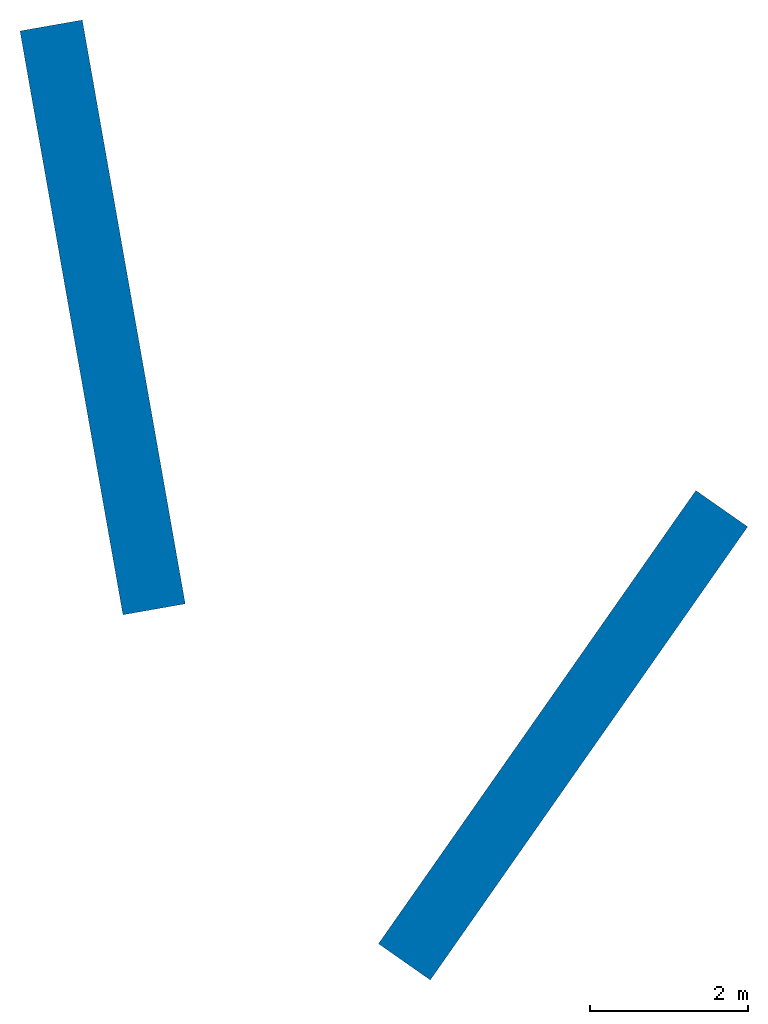
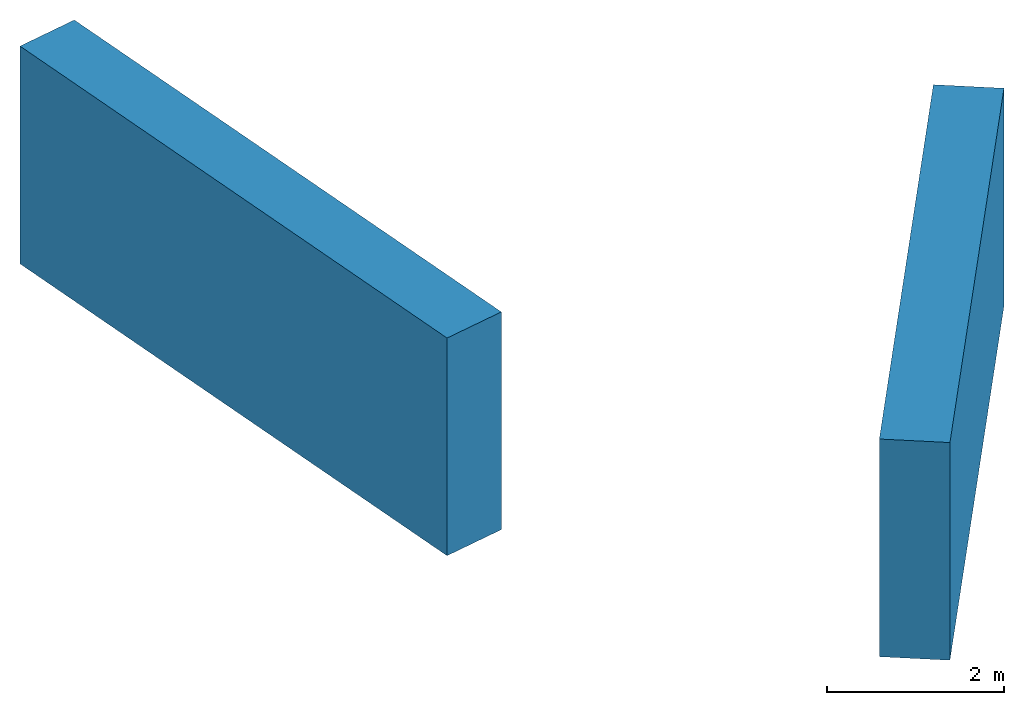
# One storey: 2 walls.
"""IFC4 building model written with IfcOpenShell, lengths in metres."""

from ifc_helpers import new_model, entity, si_unit, converted_unit, frame, origin_with_axes, origin_2d_with_axis, place, context, subcontext, project, spatial, indexed_curve, outline, extrude, material, layer, layer_set, layer_usage, type_object, element, save


model = new_model("IFC4")

# Units and contexts
model_context = context("Model", 3, precision=1e-05, world=origin_with_axes())
plan_context = context("Plan", 2, precision=1e-05, world=origin_2d_with_axis())
body_context = subcontext(model_context, "Body", "Model", "MODEL_VIEW")
ifc_project = project(units=[converted_unit("PLANEANGLEUNIT", "degree", entity("IfcReal", 0.0174532925199433), si_unit("PLANEANGLEUNIT", "RADIAN"), dimensions=[0, 0, 0, 0, 0, 0, 0]), si_unit("AREAUNIT", "SQUARE_METRE"), si_unit("VOLUMEUNIT", "CUBIC_METRE"), si_unit("LENGTHUNIT", "METRE")], contexts=[model_context, plan_context])

# Site, building, storey
site_placement = place(None, origin_with_axes())
site = spatial("IfcSite", under=ifc_project, at=site_placement)
building_placement = place(site_placement, origin_with_axes())
building = spatial("IfcBuilding", under=site, at=building_placement, Name="Building")
storey_placement = place(building_placement, origin_with_axes())
storey = spatial("IfcBuildingStorey", under=building, at=storey_placement, Name="Storey")

# Walls
ifc_material = material(Name="Cls")
ifc_layer = layer(ifc_material, 0.800000011920929)
ifc_layer_set = layer_set([ifc_layer])
ifc_layer_usage_1 = layer_usage(ifc_layer_set, "AXIS2", "POSITIVE", 0.0)
wall_type = type_object("IfcWallType", Name="strutturale", PredefinedType="USERDEFINED", material=ifc_layer_set)
wall_1_placement = place(storey_placement, frame((-1.73205053806305, 1.00000047683716, 0.0), z_axis=(0.0, 0.0, 1.0), x_axis=(-0.173648071177141, 0.984807771789225, 0.0)))
element("IfcWall", 1, at=wall_1_placement, inside=storey, type_object=wall_type, material=ifc_layer_usage_1, Name="Wall_001", context=body_context, shape_type="SweptSolid", body=[
    extrude(outline(indexed_curve([(0.0, 0.0), (0.0, 0.800000011920929), (7.50000007152557, 0.800000011920929), (7.50000007152557, 0.0), (0.0, 0.0)], self_intersect=False)), origin_with_axes(), (0.0, 0.0, 1.0), 3.0),
])
ifc_layer_usage_2 = layer_usage(ifc_layer_set, "AXIS2", "POSITIVE", 0.0)
wall_2_placement = place(storey_placement, frame((1.36808061599731, -3.75877046585083, 0.0), z_axis=(0.0, 0.0, 1.0), x_axis=(0.573576399695256, 0.819152069955651, 0.0)))
element("IfcWall", 2, at=wall_2_placement, inside=storey, type_object=wall_type, material=ifc_layer_usage_2, Name="Wall_002", context=body_context, shape_type="SweptSolid", body=[
    extrude(outline(indexed_curve([(0.0, 0.0), (0.0, 0.800000011920929), (6.99999945504323, 0.800000011920929), (6.99999945504323, 0.0), (0.0, 0.0)], self_intersect=False)), origin_with_axes(), (0.0, 0.0, 1.0), 3.0),
])

save(model, "model.ifc")
